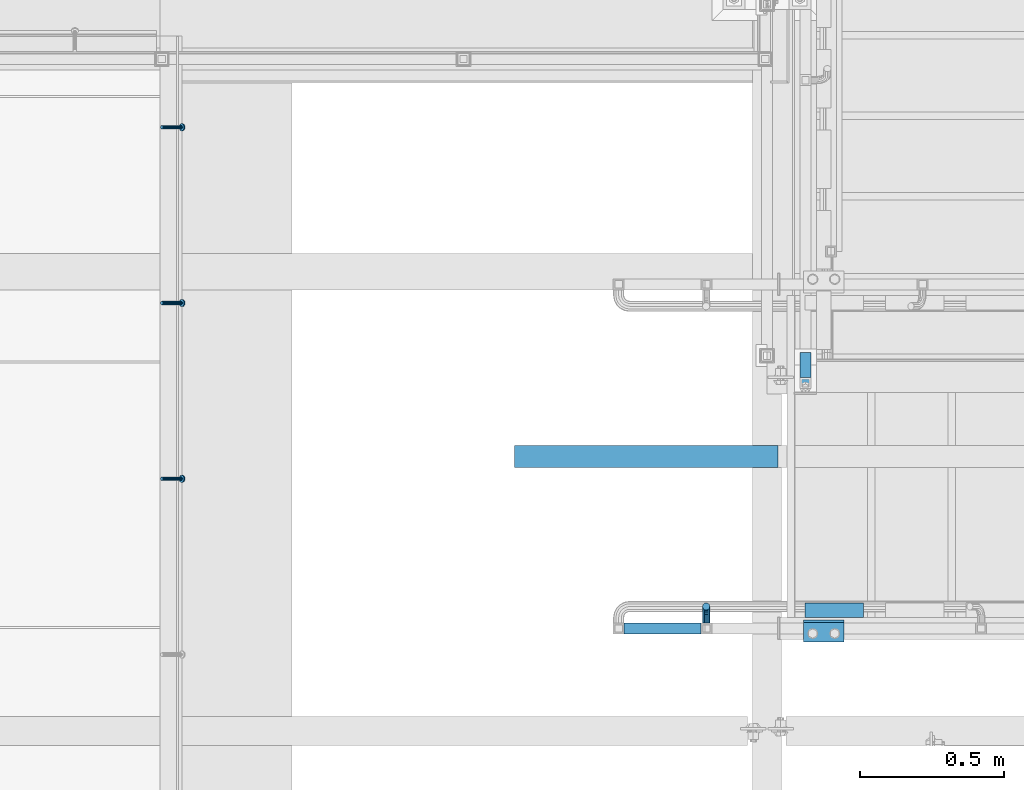
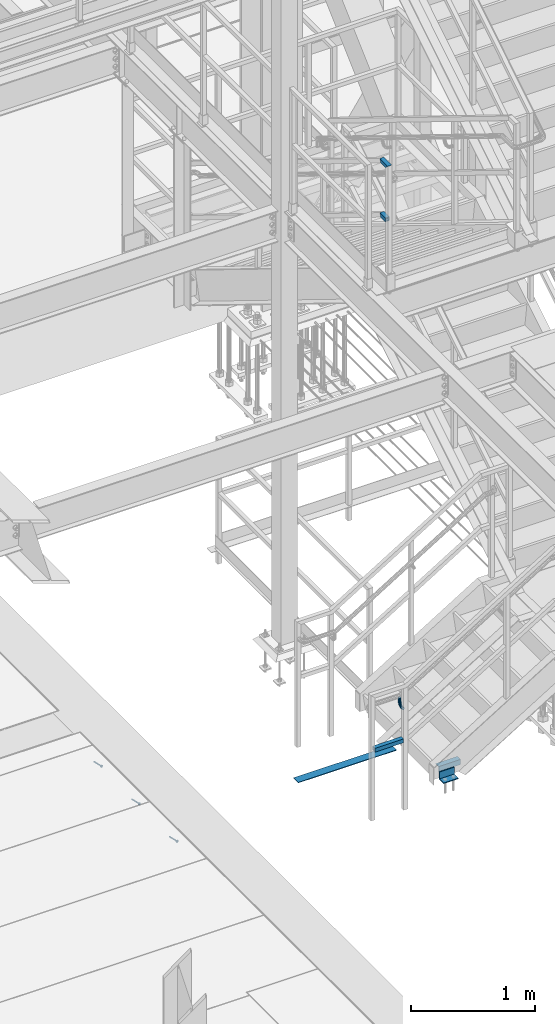
# One storey, part 2060 of 3843: 6 beams, 4 members, 5 elements without a shape of their own.
"""IFC2X3 building model written with IfcOpenShell, lengths in millimetres."""

import ifcopenshell
import ifcopenshell.guid

model = None  # the IFC model being written
_history = None  # IfcOwnerHistory: only IFC2X3 demands one
_inside = {}  # id of a spatial element -> (the spatial element, [elements in it])
_under = {}  # id of a project, library or spatial element -> (it, [spatial elements below it])
_declared = {}  # id of a project -> (the project, [libraries it declares])
_typed = {}  # id of a type object -> (the type object, [elements of that type])
_made_of = {}  # id of a material, layer set ... -> (it, [elements and type objects made of it])


def new_model(schema):
    """Start an empty IFC model of exactly this schema.

    Asked for "IFC4X3", IfcOpenShell would pick the latest addendum, in which some entities
    have other attributes; the version numbers below select the first issue.
    IFC2X3 requires an IfcOwnerHistory on every rooted entity: one is made here for all.
    """
    global model, _history
    if schema == "IFC4X3":
        model = ifcopenshell.file(schema_version=(4, 3, 0, 0))
    else:
        model = ifcopenshell.file(schema=schema)
    _inside.clear()
    _under.clear()
    _declared.clear()
    _typed.clear()
    _made_of.clear()
    _history = None
    if model.schema == "IFC2X3":
        org = make("IfcOrganization", Name="unknown")
        user = make(
            "IfcPersonAndOrganization",
            ThePerson=make("IfcPerson", FamilyName="unknown"),
            TheOrganization=org,
        )
        app = make(
            "IfcApplication",
            ApplicationDeveloper=org,
            Version="unknown",
            ApplicationFullName="unknown",
            ApplicationIdentifier="unknown",
        )
        _history = make(
            "IfcOwnerHistory",
            OwningUser=user,
            OwningApplication=app,
            ChangeAction="ADDED",
            CreationDate=0,
        )
    return model


def make(cls, **values):
    """One entity of the class cls with the attributes given. An attribute that is None is left unset."""
    return model.create_entity(
        cls, **{name: value for name, value in values.items() if value is not None}
    )


def rooted(cls, **values):
    """An entity with a GlobalId (a new one), such as an element, a storey or a relation."""
    return make(cls, GlobalId=ifcopenshell.guid.new(), OwnerHistory=_history, **values)


def si_unit(unit_type, name, prefix=None):
    """IfcSIUnit, for example si_unit("LENGTHUNIT", "METRE", prefix="MILLI")."""
    return make("IfcSIUnit", UnitType=unit_type, Prefix=prefix, Name=name)


def assignment(units):
    """IfcUnitAssignment: the units of a project."""
    return None if units is None else make("IfcUnitAssignment", Units=units)


def point(xyz):
    """IfcCartesianPoint."""
    return None if xyz is None else make("IfcCartesianPoint", Coordinates=xyz)


def direction(xyz):
    """IfcDirection."""
    return None if xyz is None else make("IfcDirection", DirectionRatios=xyz)


def frame(location, z_axis=None, x_axis=None):
    """IfcAxis2Placement3D, a coordinate frame: its origin and axes. An axis left out is left unset."""
    return make(
        "IfcAxis2Placement3D",
        Location=point(location),
        Axis=direction(z_axis),
        RefDirection=direction(x_axis),
    )


def origin_with_axes():
    """The frame at (0, 0, 0) with the z axis (0, 0, 1) and the x axis (1, 0, 0) written out."""
    return frame((0.0, 0.0, 0.0), z_axis=(0.0, 0.0, 1.0), x_axis=(1.0, 0.0, 0.0))


def place(relative_to, where):
    """IfcLocalPlacement: puts the frame where relative to a parent placement (None: the world)."""
    return make(
        "IfcLocalPlacement", PlacementRelTo=relative_to, RelativePlacement=where
    )


def context(
    kind, dimensions, precision=None, world=None, true_north=None, identifier=None
):
    """IfcGeometricRepresentationContext, for example the 3D "Model" context."""
    return make(
        "IfcGeometricRepresentationContext",
        ContextIdentifier=identifier,
        ContextType=kind,
        CoordinateSpaceDimension=dimensions,
        Precision=precision,
        WorldCoordinateSystem=world,
        TrueNorth=true_north,
    )


def subcontext(parent, identifier, kind, view, scale=None):
    """IfcGeometricRepresentationSubContext, for example "Body" below "Model"."""
    return make(
        "IfcGeometricRepresentationSubContext",
        ContextIdentifier=identifier,
        ContextType=kind,
        ParentContext=parent,
        TargetScale=scale,
        TargetView=view,
    )


def project(units=None, contexts=None):
    """IfcProject with its units and contexts."""
    return rooted(
        "IfcProject",
        Name="project",
        RepresentationContexts=contexts,
        UnitsInContext=assignment(units),
    )


def spatial(cls, under=None, at=None, **own):
    """A site, building, storey or space (cls), placed at a placement, below another one or the project."""
    s = rooted(cls, ObjectPlacement=at, **own)
    if under is not None:
        _under.setdefault(under.id(), (under, []))[1].append(s)
    return s


def faces_of(points, faces, orient=None, outer=None):
    """IfcFace entities. A face is a list of loops; a loop is a list of indices into points, from 0.

    orient and outer hold one flag for each loop. By default every Orientation is true, the
    first loop of a face is its IfcFaceOuterBound and the others are IfcFaceBound.
    """
    made = []
    for i, loops in enumerate(faces):
        bounds = []
        for j, loop in enumerate(loops):
            is_outer = j == 0 if outer is None else outer[i][j]
            bounds.append(
                make(
                    "IfcFaceOuterBound" if is_outer else "IfcFaceBound",
                    Bound=make("IfcPolyLoop", Polygon=[points[k] for k in loop]),
                    Orientation=True if orient is None else orient[i][j],
                )
            )
        made.append(make("IfcFace", Bounds=bounds))
    return made


def faceted_brep(points, faces, orient=None, outer=None, voids=None):
    """IfcFacetedBrep: a solid bounded by flat faces; with voids (closed shells), ...WithVoids."""
    shared = [point(p) for p in points]
    hull = make("IfcClosedShell", CfsFaces=faces_of(shared, faces, orient, outer))
    if voids is None:
        return make("IfcFacetedBrep", Outer=hull)
    return make(
        "IfcFacetedBrepWithVoids",
        Outer=hull,
        Voids=[
            make(cls, CfsFaces=faces_of(shared, fs, o, b)) for cls, fs, o, b in voids
        ],
    )


def shape(context_of_items, identifier, shape_type, items):
    """IfcShapeRepresentation: the items that make up one representation, for example the "Body"."""
    return make(
        "IfcShapeRepresentation",
        ContextOfItems=context_of_items,
        RepresentationIdentifier=identifier,
        RepresentationType=shape_type,
        Items=items,
    )


def material(Name=None, Category=None):
    """IfcMaterial."""
    return make("IfcMaterial", Name=Name, Category=Category)


def made_of(thing, what):
    """Note that an element or type object is made of a material, layer set ...; save() writes the relation."""
    if what is not None:
        _made_of.setdefault(what.id(), (what, []))[1].append(thing)
    return thing


def type_object(cls, material=None, **own):
    """A type object (cls), such as IfcWallType, which elements share."""
    return made_of(rooted(cls, **own), material)


def element(
    cls,
    number,
    at=None,
    inside=None,
    cuts=None,
    type_object=None,
    material=None,
    context=None,
    identifier="Body",
    shape_type=None,
    held_by="IfcProductDefinitionShape",
    body=None,
    shapes=None,
    **own,
):
    """One element of the class cls, such as IfcWall. Its Tag is "e" and its number.

    at: its placement. inside: the storey or other place that contains it. cuts: it is an
    opening in that element (IfcRelVoidsElement). A single representation is given by context,
    identifier, shape_type and body (its items); several are given by shapes. held_by: the class
    of the entity that holds the representations. save() writes the other relations.
    """
    e = rooted(cls, Tag="e%d" % number, ObjectPlacement=at, **own)
    if body is not None:
        shapes = [shape(context, identifier, shape_type, body)]
    if shapes is not None:
        e.Representation = make(held_by, Representations=shapes)
    if inside is not None:
        _inside.setdefault(inside.id(), (inside, []))[1].append(e)
    if cuts is not None:
        rooted(
            "IfcRelVoidsElement", RelatingBuildingElement=cuts, RelatedOpeningElement=e
        )
    if type_object is not None:
        _typed.setdefault(type_object.id(), (type_object, []))[1].append(e)
    return made_of(e, material)


def aggregate(whole, parts):
    """IfcRelAggregates: a whole, such as a stair, and the parts it consists of."""
    return rooted("IfcRelAggregates", RelatingObject=whole, RelatedObjects=parts)


def save(model, path):
    """Write the relations noted so far, then the file.

    IfcRelAggregates (storeys below a building ...), IfcRelContainedInSpatialStructure (elements
    in a storey), IfcRelDefinesByType, IfcRelAssociatesMaterial and IfcRelDeclares: one each for
    every whole, place, type object, material and project.
    """
    for whole, parts in _under.values():
        aggregate(whole, parts)
    for where, things in _inside.values():
        rooted(
            "IfcRelContainedInSpatialStructure",
            RelatedElements=things,
            RelatingStructure=where,
        )
    for kind, things in _typed.values():
        rooted("IfcRelDefinesByType", RelatedObjects=things, RelatingType=kind)
    for what, things in _made_of.values():
        rooted("IfcRelAssociatesMaterial", RelatedObjects=things, RelatingMaterial=what)
    for by, libraries in _declared.values():
        rooted("IfcRelDeclares", RelatingContext=by, RelatedDefinitions=libraries)
    model.write(path)


model = new_model("IFC2X3")

# Units and contexts
model_context = context("Model", 3, precision=1e-05, world=origin_with_axes())
body_context = subcontext(model_context, "Body", "Model", "MODEL_VIEW")
ifc_project = project(units=[si_unit("LENGTHUNIT", "METRE", prefix="MILLI"), si_unit("AREAUNIT", "SQUARE_METRE"), si_unit("VOLUMEUNIT", "CUBIC_METRE"), si_unit("MASSUNIT", "GRAM", prefix="KILO"), si_unit("TIMEUNIT", "SECOND"), si_unit("PLANEANGLEUNIT", "RADIAN"), si_unit("SOLIDANGLEUNIT", "STERADIAN"), si_unit("THERMODYNAMICTEMPERATUREUNIT", "DEGREE_CELSIUS"), si_unit("LUMINOUSINTENSITYUNIT", "LUMEN")], contexts=[model_context])

# Site, building, storey
site_placement = place(None, origin_with_axes())
site = spatial("IfcSite", under=ifc_project, at=site_placement, CompositionType="ELEMENT")
building_placement = place(site_placement, origin_with_axes())
building = spatial("IfcBuilding", under=site, at=building_placement, Name="Undefined", CompositionType="ELEMENT")
storey_placement = place(building_placement, origin_with_axes())
storey = spatial("IfcBuildingStorey", under=building, at=storey_placement, Name="Undefined", CompositionType="ELEMENT", Elevation=0.0)

# Assembly, members
assembly_1_placement = place(storey_placement, origin_with_axes())
assembly_1 = element("IfcElementAssembly", 1, at=assembly_1_placement, inside=storey, Name="ANGLE", AssemblyPlace="NOTDEFINED", PredefinedType="RIGID_FRAME")
ifc_material_1 = material(Name="STEEL/A108")
member_type_1 = type_object("IfcMemberType", PredefinedType="NOTDEFINED")
member_1_placement = place(assembly_1_placement, frame((50892.075, 18527.7125, 30397.4500030517), z_axis=(0.0, 1.0, 0.0), x_axis=(0.707106781186548, 0.0, -0.707106781186548)))
member_1 = element("IfcMember", 2, at=member_1_placement, type_object=member_type_1, material=ifc_material_1, Name="HEADED STUD ANCHOR", context=body_context, shape_type="Brep", body=[
    faceted_brep([(7.27595761418343e-12, -3.18000006675175, 5.5), (0.0, -5.49999999998363, 3.1800000667572), (94.4879985803855, -5.50000000011278, 3.1800000667572), (94.4879985803782, -3.18000006687362, 5.5), (0.0, -6.3499999046162, 0.0), (94.4879985803855, -6.34999990474535, 0.0), (0.0, -5.49999999998363, -3.1800000667572), (94.4879985803855, -5.50000000011278, -3.1800000667572), (7.27595761418343e-12, -3.18000006675175, -5.5), (94.4879985803782, -3.18000006687362, -5.5), (7.27595761418343e-12, -1.81898940354586e-12, -6.34999990463257), (94.4879985803782, -1.20053300634027e-10, -6.34999990463257), (0.0, 3.18000006675175, -5.5), (94.4879985803709, 3.18000006663351, -5.5), (7.27595761418343e-12, 5.49999999998363, -3.1800000667572), (94.4879985803709, 5.49999999987267, -3.1800000667572), (7.27595761418343e-12, 6.3499999046162, 0.0), (94.4879985803673, 6.34999990450706, 0.0), (7.27595761418343e-12, 5.49999999998363, 3.1800000667572), (94.4879985803709, 5.49999999987267, 3.1800000667572), (0.0, 3.18000006675175, 5.5), (94.4879985803709, 3.18000006663351, 5.5), (7.27595761418343e-12, -1.81898940354586e-12, 6.34999990463257), (94.4879985803782, -1.20053300634027e-10, 6.34999990463257), (96.5199985498621, -10.9899997712273, 6.34999990463257), (96.5199985498548, -6.34000015270249, 10.9899997711182), (96.5199985498621, -12.6999998093743, 0.0), (96.5199985498621, -10.9899997712273, -6.34999990463257), (96.5199985498548, -6.34000015270249, -10.9899997711182), (96.5199985498475, -1.21872290037572e-10, -12.6899995803833), (96.5199985498402, 6.34000015245874, -10.9899997711182), (96.519998549833, 10.9899997709817, -6.34999990463257), (96.519998549833, 12.6999998091305, 0.0), (96.519998549833, 10.9899997709817, 6.34999990463257), (96.5199985498402, 6.34000015245874, 10.9899997711182), (96.5199985498475, -1.21872290037572e-10, 12.6899995803833), (101.599998473539, -10.9899997712328, 6.34999990463257), (101.599998473532, -6.34000015270976, 10.9899997711182), (101.599998473539, -12.6999998093797, 0.0), (101.599998473539, -10.9899997712328, -6.34999990463257), (101.599998473532, -6.34000015270976, -10.9899997711182), (101.599998473524, -1.29148247651756e-10, -12.6899995803833), (101.599998473517, 6.34000015245329, -10.9899997711182), (101.59999847351, 10.9899997709763, -6.34999990463257), (101.599998473503, 12.6999998091196, 0.0), (101.59999847351, 10.9899997709763, 6.34999990463257), (101.599998473517, 6.34000015245329, 10.9899997711182), (101.599998473524, -1.29148247651756e-10, 12.6899995803833)], [[[0, 1, 2, 3]], [[1, 4, 5, 2]], [[4, 6, 7, 5]], [[6, 8, 9, 7]], [[8, 10, 11, 9]], [[10, 12, 13, 11]], [[12, 14, 15, 13]], [[14, 16, 17, 15]], [[16, 18, 19, 17]], [[18, 20, 21, 19]], [[20, 22, 23, 21]], [[22, 0, 3, 23]], [[22, 20, 18, 16, 14, 12, 10, 8, 6, 4, 1, 0]], [[3, 2, 24, 25]], [[2, 5, 26, 24]], [[5, 7, 27, 26]], [[7, 9, 28, 27]], [[9, 11, 29, 28]], [[11, 13, 30, 29]], [[13, 15, 31, 30]], [[15, 17, 32, 31]], [[17, 19, 33, 32]], [[19, 21, 34, 33]], [[21, 23, 35, 34]], [[23, 3, 25, 35]], [[25, 24, 36, 37]], [[24, 26, 38, 36]], [[26, 27, 39, 38]], [[27, 28, 40, 39]], [[28, 29, 41, 40]], [[29, 30, 42, 41]], [[30, 31, 43, 42]], [[31, 32, 44, 43]], [[32, 33, 45, 44]], [[33, 34, 46, 45]], [[34, 35, 47, 46]], [[35, 25, 37, 47]], [[38, 39, 40, 41, 42, 43, 44, 45, 46, 47, 37, 36]]]),
])
member_2_placement = place(assembly_1_placement, frame((50892.075, 19137.3125, 30397.4500030517), z_axis=(0.0, 1.0, 0.0), x_axis=(0.707106781186548, 0.0, -0.707106781186548)))
member_2 = element("IfcMember", 3, at=member_2_placement, type_object=member_type_1, material=ifc_material_1, Name="HEADED STUD ANCHOR", context=body_context, shape_type="Brep", body=[
    faceted_brep([(7.27595761418343e-12, -3.18000006675175, 5.5), (0.0, -5.49999999998363, 3.1800000667572), (94.4879985803855, -5.50000000011278, 3.1800000667572), (94.4879985803782, -3.18000006687362, 5.5), (0.0, -6.3499999046162, 0.0), (94.4879985803855, -6.34999990474535, 0.0), (0.0, -5.49999999998363, -3.1800000667572), (94.4879985803855, -5.50000000011278, -3.1800000667572), (7.27595761418343e-12, -3.18000006675175, -5.5), (94.4879985803782, -3.18000006687362, -5.5), (7.27595761418343e-12, -1.81898940354586e-12, -6.34999990463257), (94.4879985803782, -1.20053300634027e-10, -6.34999990463257), (0.0, 3.18000006675175, -5.5), (94.4879985803709, 3.18000006663351, -5.5), (7.27595761418343e-12, 5.49999999998363, -3.1800000667572), (94.4879985803709, 5.49999999987267, -3.1800000667572), (7.27595761418343e-12, 6.3499999046162, 0.0), (94.4879985803673, 6.34999990450706, 0.0), (7.27595761418343e-12, 5.49999999998363, 3.1800000667572), (94.4879985803709, 5.49999999987267, 3.1800000667572), (0.0, 3.18000006675175, 5.5), (94.4879985803709, 3.18000006663351, 5.5), (7.27595761418343e-12, -1.81898940354586e-12, 6.34999990463257), (94.4879985803782, -1.20053300634027e-10, 6.34999990463257), (96.5199985498621, -10.9899997712273, 6.34999990463257), (96.5199985498548, -6.34000015270249, 10.9899997711182), (96.5199985498621, -12.6999998093743, 0.0), (96.5199985498621, -10.9899997712273, -6.34999990463257), (96.5199985498548, -6.34000015270249, -10.9899997711182), (96.5199985498475, -1.21872290037572e-10, -12.6899995803833), (96.5199985498402, 6.34000015245874, -10.9899997711182), (96.519998549833, 10.9899997709817, -6.34999990463257), (96.519998549833, 12.6999998091305, 0.0), (96.519998549833, 10.9899997709817, 6.34999990463257), (96.5199985498402, 6.34000015245874, 10.9899997711182), (96.5199985498475, -1.21872290037572e-10, 12.6899995803833), (101.599998473539, -10.9899997712328, 6.34999990463257), (101.599998473532, -6.34000015270976, 10.9899997711182), (101.599998473539, -12.6999998093797, 0.0), (101.599998473539, -10.9899997712328, -6.34999990463257), (101.599998473532, -6.34000015270976, -10.9899997711182), (101.599998473524, -1.29148247651756e-10, -12.6899995803833), (101.599998473517, 6.34000015245329, -10.9899997711182), (101.59999847351, 10.9899997709763, -6.34999990463257), (101.599998473503, 12.6999998091196, 0.0), (101.59999847351, 10.9899997709763, 6.34999990463257), (101.599998473517, 6.34000015245329, 10.9899997711182), (101.599998473524, -1.29148247651756e-10, 12.6899995803833)], [[[0, 1, 2, 3]], [[1, 4, 5, 2]], [[4, 6, 7, 5]], [[6, 8, 9, 7]], [[8, 10, 11, 9]], [[10, 12, 13, 11]], [[12, 14, 15, 13]], [[14, 16, 17, 15]], [[16, 18, 19, 17]], [[18, 20, 21, 19]], [[20, 22, 23, 21]], [[22, 0, 3, 23]], [[22, 20, 18, 16, 14, 12, 10, 8, 6, 4, 1, 0]], [[3, 2, 24, 25]], [[2, 5, 26, 24]], [[5, 7, 27, 26]], [[7, 9, 28, 27]], [[9, 11, 29, 28]], [[11, 13, 30, 29]], [[13, 15, 31, 30]], [[15, 17, 32, 31]], [[17, 19, 33, 32]], [[19, 21, 34, 33]], [[21, 23, 35, 34]], [[23, 3, 25, 35]], [[25, 24, 36, 37]], [[24, 26, 38, 36]], [[26, 27, 39, 38]], [[27, 28, 40, 39]], [[28, 29, 41, 40]], [[29, 30, 42, 41]], [[30, 31, 43, 42]], [[31, 32, 44, 43]], [[32, 33, 45, 44]], [[33, 34, 46, 45]], [[34, 35, 47, 46]], [[35, 25, 37, 47]], [[38, 39, 40, 41, 42, 43, 44, 45, 46, 47, 37, 36]]]),
])
member_3_placement = place(assembly_1_placement, frame((50892.075, 19746.9125, 30397.4500030517), z_axis=(0.0, 1.0, 0.0), x_axis=(0.707106781186548, 0.0, -0.707106781186548)))
member_3 = element("IfcMember", 4, at=member_3_placement, type_object=member_type_1, material=ifc_material_1, Name="HEADED STUD ANCHOR", context=body_context, shape_type="Brep", body=[
    faceted_brep([(7.27595761418343e-12, -3.18000006675175, 5.5), (0.0, -5.49999999998363, 3.1800000667572), (94.4879985803855, -5.50000000011278, 3.1800000667572), (94.4879985803782, -3.18000006687362, 5.5), (0.0, -6.3499999046162, 0.0), (94.4879985803855, -6.34999990474535, 0.0), (0.0, -5.49999999998363, -3.1800000667572), (94.4879985803855, -5.50000000011278, -3.1800000667572), (7.27595761418343e-12, -3.18000006675175, -5.5), (94.4879985803782, -3.18000006687362, -5.5), (7.27595761418343e-12, -1.81898940354586e-12, -6.34999990463257), (94.4879985803782, -1.20053300634027e-10, -6.34999990463257), (0.0, 3.18000006675175, -5.5), (94.4879985803709, 3.18000006663351, -5.5), (7.27595761418343e-12, 5.49999999998363, -3.1800000667572), (94.4879985803709, 5.49999999987267, -3.1800000667572), (7.27595761418343e-12, 6.3499999046162, 0.0), (94.4879985803673, 6.34999990450706, 0.0), (7.27595761418343e-12, 5.49999999998363, 3.1800000667572), (94.4879985803709, 5.49999999987267, 3.1800000667572), (0.0, 3.18000006675175, 5.5), (94.4879985803709, 3.18000006663351, 5.5), (7.27595761418343e-12, -1.81898940354586e-12, 6.34999990463257), (94.4879985803782, -1.20053300634027e-10, 6.34999990463257), (96.5199985498621, -10.9899997712273, 6.34999990463257), (96.5199985498548, -6.34000015270249, 10.9899997711182), (96.5199985498621, -12.6999998093743, 0.0), (96.5199985498621, -10.9899997712273, -6.34999990463257), (96.5199985498548, -6.34000015270249, -10.9899997711182), (96.5199985498475, -1.21872290037572e-10, -12.6899995803833), (96.5199985498402, 6.34000015245874, -10.9899997711182), (96.519998549833, 10.9899997709817, -6.34999990463257), (96.519998549833, 12.6999998091305, 0.0), (96.519998549833, 10.9899997709817, 6.34999990463257), (96.5199985498402, 6.34000015245874, 10.9899997711182), (96.5199985498475, -1.21872290037572e-10, 12.6899995803833), (101.599998473539, -10.9899997712328, 6.34999990463257), (101.599998473532, -6.34000015270976, 10.9899997711182), (101.599998473539, -12.6999998093797, 0.0), (101.599998473539, -10.9899997712328, -6.34999990463257), (101.599998473532, -6.34000015270976, -10.9899997711182), (101.599998473524, -1.29148247651756e-10, -12.6899995803833), (101.599998473517, 6.34000015245329, -10.9899997711182), (101.59999847351, 10.9899997709763, -6.34999990463257), (101.599998473503, 12.6999998091196, 0.0), (101.59999847351, 10.9899997709763, 6.34999990463257), (101.599998473517, 6.34000015245329, 10.9899997711182), (101.599998473524, -1.29148247651756e-10, 12.6899995803833)], [[[0, 1, 2, 3]], [[1, 4, 5, 2]], [[4, 6, 7, 5]], [[6, 8, 9, 7]], [[8, 10, 11, 9]], [[10, 12, 13, 11]], [[12, 14, 15, 13]], [[14, 16, 17, 15]], [[16, 18, 19, 17]], [[18, 20, 21, 19]], [[20, 22, 23, 21]], [[22, 0, 3, 23]], [[22, 20, 18, 16, 14, 12, 10, 8, 6, 4, 1, 0]], [[3, 2, 24, 25]], [[2, 5, 26, 24]], [[5, 7, 27, 26]], [[7, 9, 28, 27]], [[9, 11, 29, 28]], [[11, 13, 30, 29]], [[13, 15, 31, 30]], [[15, 17, 32, 31]], [[17, 19, 33, 32]], [[19, 21, 34, 33]], [[21, 23, 35, 34]], [[23, 3, 25, 35]], [[25, 24, 36, 37]], [[24, 26, 38, 36]], [[26, 27, 39, 38]], [[27, 28, 40, 39]], [[28, 29, 41, 40]], [[29, 30, 42, 41]], [[30, 31, 43, 42]], [[31, 32, 44, 43]], [[32, 33, 45, 44]], [[33, 34, 46, 45]], [[34, 35, 47, 46]], [[35, 25, 37, 47]], [[38, 39, 40, 41, 42, 43, 44, 45, 46, 47, 37, 36]]]),
])
aggregate(assembly_1, [member_1, member_2, member_3])

# Assembly, beam
assembly_2_placement = place(storey_placement, origin_with_axes())
assembly_2 = element("IfcElementAssembly", 5, at=assembly_2_placement, inside=storey, Name="STAIR", AssemblyPlace="NOTDEFINED", PredefinedType="RIGID_FRAME")
ifc_material_2 = material(Name="STEEL/A36")
beam_type_1 = type_object("IfcBeamType", Name="L3X3X3/8", PredefinedType="NOTDEFINED")
beam_1_placement = place(assembly_2_placement, frame((53257.45, 18000.6625000644, 30518.1), z_axis=(0.0, -1.0, 0.0), x_axis=(-1.0, 0.0, 0.0)))
beam_1 = element("IfcBeam", 6, at=beam_1_placement, type_object=beam_type_1, material=ifc_material_2, Name="CLEAT", ObjectType="L3X3X3/8", context=body_context, shape_type="Brep", body=[
    faceted_brep([(0.0, 38.0999999999985, -38.0999999999985), (0.0, 38.0999999999985, 38.0999999999985), (139.699999999997, 38.0999999999985, 38.0999999999985), (139.699999999997, 38.0999999999985, -38.0999999999985), (0.0, 28.5750000000007, 38.0999999999985), (139.699999999997, 28.5750000000007, 38.0999999999985), (0.0, 28.5750000000007, -28.5750000000007), (139.699999999997, 28.5750000000007, -28.5750000000007), (0.0, -38.0999999999985, -28.5750000000007), (139.699999999997, -38.0999999999985, -28.5750000000007), (0.0, -38.0999999999985, -38.0999999999985), (139.699999999997, -38.0999999999985, -38.0999999999985)], [[[0, 1, 2, 3]], [[1, 4, 5, 2]], [[4, 6, 7, 5]], [[6, 8, 9, 7]], [[8, 10, 11, 9]], [[10, 0, 3, 11]], [[5, 7, 9, 11, 3, 2]], [[10, 8, 6, 4, 1, 0]]]),
])

# Assembly, beams
assembly_3_placement = place(storey_placement, origin_with_axes())
assembly_3 = element("IfcElementAssembly", 7, at=assembly_3_placement, inside=storey, Name="RAIL", AssemblyPlace="NOTDEFINED", PredefinedType="RIGID_FRAME")
ifc_material_3 = material()
beam_type_2 = type_object("IfcBeamType", Name="HSS1-1/2X1-1/2X1/4", PredefinedType="NOTDEFINED")
beam_2_placement = place(assembly_3_placement, frame((53124.1, 18961.0999971375, 35483.7999969347), z_axis=(0.0, 0.0, 1.0), x_axis=(0.0, -1.0, 0.0)))
beam_2 = element("IfcBeam", 8, at=beam_2_placement, type_object=beam_type_2, material=ifc_material_3, Name="RAIL", ObjectType="HSS1-1/2X1-1/2X1/4", context=body_context, shape_type="Brep", body=[
    faceted_brep([(3.59463564452017, 12.6999993300014, -12.6999993299978), (3.59463564452017, -12.6999993300014, -12.6999993299978), (82.5500000532629, -12.6999993300014, -12.6999993299978), (82.5500000532629, 12.6999993300014, -12.6999993299978), (-3.59463560431323, -12.6999993300014, 12.6999993299978), (82.5500000532629, -12.6999993300014, 12.6999993299978), (-3.59463560431323, 12.6999993300014, 12.6999993299978), (82.5500000532629, 12.6999993300014, 12.6999993299978), (5.39195352466777, 19.0499992350015, -19.0499992350015), (-5.39195348444628, 19.0499992350015, 19.0499992350015), (82.5500000532629, 19.0499992350015, 19.0499992350015), (82.5500000532629, 19.0499992350015, -19.0499992350015), (-5.39195348444628, -19.0499992350015, 19.0499992350015), (82.5500000532629, -19.0499999999993, 19.0499992350015), (5.39195352466777, -19.0499992350015, -19.0499992350015), (82.5500000532629, -19.0499992350015, -19.0499992350015)], [[[0, 1, 2, 3]], [[1, 4, 5, 2]], [[4, 6, 7, 5]], [[6, 0, 3, 7]], [[8, 9, 10, 11]], [[9, 12, 13, 10]], [[12, 14, 15, 13]], [[14, 8, 11, 15]], [[13, 15, 11, 10], [5, 7, 3, 2]], [[14, 12, 9, 8], [6, 4, 1, 0]]]),
])
beam_3_placement = place(assembly_3_placement, frame((53124.1, 18859.4999999849, 36017.199996934), z_axis=(0.0, 0.0, -1.0), x_axis=(0.0, 1.0, 0.0)))
beam_3 = element("IfcBeam", 9, at=beam_3_placement, type_object=beam_type_2, material=ifc_material_3, Name="RAIL", ObjectType="HSS1-1/2X1-1/2X1/4", context=body_context, shape_type="Brep", body=[
    faceted_brep([(-12.6999993309546, 12.6999993299978, -12.6999993299978), (-12.6999993309546, -12.6999993299978, -12.6999993299978), (105.194632755753, -12.6999993299978, -12.6999993299978), (105.194632755753, 12.6999993299978, -12.6999993299978), (12.6999993290483, -12.6999993299978, 12.6999993299978), (98.0053615143879, -12.6999993299978, 12.6999993299978), (12.6999993290483, 12.6999993299978, 12.6999993299978), (98.0053615143879, 12.6999993299978, 12.6999993299978), (-19.0499992359546, 19.0499992350015, -19.0499992350015), (19.0499992350015, 19.0499992350015, 19.0499992350015), (96.2080436361175, 19.0499992350015, 19.0499992350015), (106.991950634023, 19.0499992350015, -19.0499992350015), (19.0499992350015, -19.0499992350015, 19.0499992350015), (96.2080436361175, -19.0499992350015, 19.0499992350015), (-19.0499992359546, -19.0499992350015, -19.0499992350015), (106.991950634023, -19.0499992350015, -19.0499992350015)], [[[0, 1, 2, 3]], [[1, 4, 5, 2]], [[4, 6, 7, 5]], [[6, 0, 3, 7]], [[8, 9, 10, 11]], [[9, 12, 13, 10]], [[12, 14, 15, 13]], [[14, 8, 11, 15]], [[13, 15, 11, 10], [5, 7, 3, 2]], [[14, 12, 9, 8], [6, 4, 1, 0]]]),
])
aggregate(assembly_3, [beam_2, beam_3])

# Assembly, beam
assembly_4_placement = place(storey_placement, origin_with_axes())
assembly_4 = element("IfcElementAssembly", 10, at=assembly_4_placement, inside=storey, Name="RAIL", AssemblyPlace="NOTDEFINED", PredefinedType="RIGID_FRAME")
beam_4_placement = place(assembly_4_placement, frame((52476.3999999909, 18008.6000001452, 31013.4), z_axis=(0.0, 0.0, 1.0), x_axis=(1.0, 0.0, 0.0)))
beam_4 = element("IfcBeam", 11, at=beam_4_placement, type_object=beam_type_2, material=ifc_material_3, Name="RAIL", ObjectType="HSS1-1/2X1-1/2X1/4", context=body_context, shape_type="Brep", body=[
    faceted_brep([(19.0499992350015, -19.0499992350015, 19.0499992350015), (19.0499992350015, -19.0499992350015, -19.0499992350015), (285.750000765285, -19.0499992350015, -19.0499992350015), (285.750000765285, -19.0499992350015, 19.0499992350015), (19.0499992350015, 19.0499992350015, 19.0499992350015), (19.0500015258804, 0.0, 19.0500000000029), (285.75000076498, 0.0, 19.0499992350015), (285.750000765285, 19.0499992350015, 19.0499992350015), (19.0499992350015, 19.0499992350015, -19.0499992350015), (285.750000765285, 19.0499992350015, -19.0499992350015), (19.0500015258804, 0.0, -19.0500000000029), (19.0499992350015, 12.6999993299978, -12.6999993299978), (19.0499992350015, 12.6999993299978, 12.6999993299978), (19.0500015258731, 0.0, 12.6999999999971), (19.0499992350015, -12.6999993299978, 12.6999993299978), (19.0499992350015, -12.6999993299978, -12.6999993299978), (19.0500015258731, 0.0, -12.6999999999971), (285.750000765009, 12.6999993300014, -12.6999993299978), (285.750000765009, 12.6999993300014, 12.6999993299978), (285.75000076498, 0.0, 12.6999993300014), (285.750000765009, -12.6999993300014, 12.6999993299978), (285.750000765009, -12.6999993300014, -12.6999993299978), (285.75000076498, 0.0, -12.6999993300014), (285.75000076498, 0.0, -19.0499992350015)], [[[0, 1, 2, 3]], [[4, 5, 0, 3, 6, 7]], [[8, 4, 7, 9]], [[10, 1, 0, 5, 4, 8], [11, 12, 13, 14, 15, 16]], [[12, 11, 17, 18]], [[14, 13, 12, 18, 19, 20]], [[15, 14, 20, 21]], [[11, 16, 15, 21, 22, 17]], [[6, 3, 2, 23, 9, 7], [21, 20, 19, 18, 17, 22]], [[1, 10, 8, 9, 23, 2]]]),
])

# Beam
beam_type_3 = type_object("IfcBeamType", Name="L2X2X3/16", PredefinedType="NOTDEFINED")
beam_5_placement = place(assembly_2_placement, frame((53325.3140030326, 18072.1000001452, 30572.5634614191), z_axis=(0.0, 1.0, 0.0), x_axis=(-1.0, 0.0, 0.0)))
beam_5 = element("IfcBeam", 12, at=beam_5_placement, type_object=beam_type_3, material=ifc_material_2, Name="ANGLE", ObjectType="L2X2X3/16", context=body_context, shape_type="Brep", body=[
    faceted_brep([(0.0, 25.4000000000015, -25.4000000000015), (0.0, 25.4000000000015, 25.4000000000015), (203.199999999997, 25.4000000000015, 25.4000000000015), (203.199999999997, 25.4000000000015, -25.4000000000015), (0.0, 20.6375000000007, 25.4000000000015), (203.199999999997, 20.6375000000007, 25.4000000000015), (0.0, 20.6375000000007, -20.6375000000007), (203.199999999997, 20.6375000000007, -20.6375000000007), (0.0, -25.4000000000015, -20.6375000000007), (203.199999999997, -25.4000000000015, -20.6375000000007), (0.0, -25.4000000000015, -25.4000000000015), (203.199999999997, -25.4000000000015, -25.4000000000015)], [[[0, 1, 2, 3]], [[1, 4, 5, 2]], [[4, 6, 7, 5]], [[6, 8, 9, 7]], [[8, 10, 11, 9]], [[10, 0, 3, 11]], [[5, 7, 9, 11, 3, 2]], [[10, 8, 6, 4, 1, 0]]]),
])

aggregate(assembly_2, [beam_1, beam_5])

beam_type_4 = type_object("IfcBeamType", PredefinedType="NOTDEFINED")
beam_6_placement = place(assembly_4_placement, frame((52779.6125002313, 18027.6500001452, 31299.1500000027), z_axis=(1.0, 0.0, 0.0), x_axis=(0.0, 1.0, 0.0)))
beam_6 = element("IfcBeam", 13, at=beam_6_placement, type_object=beam_type_4, material=ifc_material_2, Name="BRACKET ARM", context=body_context, shape_type="Brep", body=[
    faceted_brep([(0.0, -12.6999999999971, 0.0), (0.0, -10.9985226280696, -6.34999999999854), (19.0500015258731, -10.9985226280623, -6.34999999999854), (19.0500015258731, -12.6999999999971, -6.33008312433958e-10), (0.0, -6.35000000000582, -10.9985226280623), (19.0500015258731, -6.34999999999854, -10.9985226280623), (0.0, 0.0, -12.6999999999971), (19.0500015258731, 0.0, -12.6999999999971), (0.0, 6.35000000000582, -10.9985226280623), (19.0500015258731, 6.34999999999854, -10.9985226280623), (0.0, 10.9985226280696, -6.34999999999854), (19.0500015258731, 10.9985226280623, -6.34999999999854), (0.0, 12.6999999999971, 0.0), (19.0500015258731, 12.6999999999971, 0.0), (0.0, 10.9985226280696, 6.34999999999854), (19.0500015258731, 10.9985226280623, 6.34999999999854), (0.0, 6.35000000000582, 10.9985226280623), (19.0500015258731, 6.34999999999854, 10.9985226280623), (0.0, 0.0, 12.6999999999971), (19.0500015258731, 0.0, 12.6999999999971), (0.0, -6.35000000000582, 10.9985226280623), (19.0500015258731, -6.34999999999854, 10.9985226280623), (0.0, -10.9985226280696, 6.34999999999854), (19.0500015258731, -10.9985226280623, 6.34999999999854), (38.4903193060891, -8.8330803677236, -3.34694050252438e-10), (37.8391921052389, -7.26112024908798, 6.34999999974389), (36.0602795104642, -2.96644533684594, 10.9985226280041), (33.6302397149266, 2.90018969451194, 12.7000000002226), (31.2001999194181, 8.76682472604443, 10.9985226285644), (29.4212873247307, 13.061499638774, 6.35000000070431), (28.7701601240115, 14.6334597580644, 7.78527464717627e-10), (29.4212873248762, 13.0614996394288, -6.34999999929278), (31.2001999196509, 8.76682472718676, -10.9985226275603), (33.6302397151885, 2.90018969582889, -12.6999999997788), (36.0602795106824, -2.96644533571089, -10.9985226281206), (37.8391921053699, -7.26112024843314, -6.35000000026048), (53.7678987435793, 3.38210125690239, -6.3499999994383), (54.9710249311902, 2.17897506880399, 5.0931703299284e-10), (50.4808968708676, 6.66910312997061, -10.9985226273784), (45.9907688103704, 11.1592311906061, -12.6999999991458), (41.5006407498004, 15.6493592510378, -10.9985226270364), (38.213638876914, 18.9363611235749, -6.34999999884167), (37.0105126890558, 20.1394873109457, 1.20053300634027e-09), (38.2136388766667, 18.9363611228473, 6.35000000115542), (41.5006407493784, 15.6493592497718, 10.9985226290883), (45.9907688098756, 11.1592311891436, 12.7000000008557), (50.4808968704456, 6.66910312870459, 10.9985226287463), (53.7678987433319, 3.38210125617479, 6.35000000055879), (64.4111202489148, 19.3108078951118, -6.34999999821594), (65.9830803677178, 18.6596806939051, 1.77533365786076e-09), (60.1164453365491, 21.0897204901557, -10.9985226262725), (54.2498103051475, 23.5197602857806, -12.6999999981927), (48.3831752736587, 25.9498000811873, -10.9985226262434), (44.0885003610601, 27.7287126756128, -6.34999999817228), (42.516540241937, 28.3798398759754, 1.83354131877422e-09), (44.08850036074, 27.7287126747688, 6.35000000183209), (48.3831752731057, 25.9498000797321, 10.9985226298813), (54.2498103045073, 23.5197602840999, 12.7000000018088), (60.1164453359961, 21.0897204886933, 10.9985226298522), (64.4111202485947, 19.3108078942678, 6.35000000178115), (68.1485226282239, 38.0999984746086, -6.3499999967753), (69.8499999999913, 38.0999984741211, 2.92493496090174e-09), (63.500000000291, 38.0999984749651, -10.9985226249628), (57.1500000003434, 38.0999984750961, -12.6999999970722), (50.8000000002939, 38.0999984749651, -10.998522625312), (46.1514773720992, 38.0999984746086, -6.34999999737192), (44.4499999999971, 38.0999984741211, 2.58296495303512e-09), (46.1514773717645, 38.0999984736336, 6.35000000262517), (50.7999999996973, 38.0999984732771, 10.9985226308127), (57.1499999996449, 38.0999984731461, 12.700000002922), (63.4999999996944, 38.0999984732771, 10.9985226311619), (68.1485226278892, 38.0999984736336, 6.35000000322179), (68.1485226280638, 76.2000000002372, -6.34999999414867), (69.8499999999913, 76.199999999757, 5.84986992180347e-09), (63.5, 76.200000000601, -10.9985226222125), (57.1499999999942, 76.2000000007247, -12.6999999941472), (50.7999999999884, 76.200000000601, -10.9985226222125), (46.1514773719246, 76.2000000002372, -6.34999999414867), (44.4499999999971, 76.199999999757, 5.84986992180347e-09), (46.1514773719246, 76.1999999992695, 6.35000000584841), (50.7999999999884, 76.1999999989057, 10.9985226339122), (57.1499999999942, 76.199999998782, 12.700000005847), (63.5, 76.1999999989057, 10.9985226339122), (68.1485226280638, 76.1999999992695, 6.35000000584841)], [[[0, 1, 2, 3]], [[1, 4, 5, 2]], [[4, 6, 7, 5]], [[6, 8, 9, 7]], [[8, 10, 11, 9]], [[10, 12, 13, 11]], [[12, 14, 15, 13]], [[14, 16, 17, 15]], [[16, 18, 19, 17]], [[18, 20, 21, 19]], [[20, 22, 23, 21]], [[22, 0, 3, 23]], [[22, 20, 18, 16, 14, 12, 10, 8, 6, 4, 1, 0]], [[23, 3, 24, 25]], [[21, 23, 25, 26]], [[19, 21, 26, 27]], [[17, 19, 27, 28]], [[15, 17, 28, 29]], [[13, 15, 29, 30]], [[11, 13, 30, 31]], [[9, 11, 31, 32]], [[7, 9, 32, 33]], [[5, 7, 33, 34]], [[2, 5, 34, 35]], [[3, 2, 35, 24]], [[35, 36, 37, 24]], [[34, 38, 36, 35]], [[33, 39, 38, 34]], [[32, 40, 39, 33]], [[31, 41, 40, 32]], [[30, 42, 41, 31]], [[29, 43, 42, 30]], [[28, 44, 43, 29]], [[27, 45, 44, 28]], [[26, 46, 45, 27]], [[25, 47, 46, 26]], [[24, 37, 47, 25]], [[36, 48, 49, 37]], [[38, 50, 48, 36]], [[39, 51, 50, 38]], [[40, 52, 51, 39]], [[41, 53, 52, 40]], [[42, 54, 53, 41]], [[43, 55, 54, 42]], [[44, 56, 55, 43]], [[45, 57, 56, 44]], [[46, 58, 57, 45]], [[47, 59, 58, 46]], [[37, 49, 59, 47]], [[48, 60, 61, 49]], [[50, 62, 60, 48]], [[51, 63, 62, 50]], [[52, 64, 63, 51]], [[53, 65, 64, 52]], [[54, 66, 65, 53]], [[55, 67, 66, 54]], [[56, 68, 67, 55]], [[57, 69, 68, 56]], [[58, 70, 69, 57]], [[59, 71, 70, 58]], [[49, 61, 71, 59]], [[61, 60, 72, 73]], [[60, 62, 74, 72]], [[62, 63, 75, 74]], [[63, 64, 76, 75]], [[64, 65, 77, 76]], [[65, 66, 78, 77]], [[66, 67, 79, 78]], [[67, 68, 80, 79]], [[68, 69, 81, 80]], [[69, 70, 82, 81]], [[70, 71, 83, 82]], [[71, 61, 73, 83]], [[74, 75, 76, 77, 78, 79, 80, 81, 82, 83, 73, 72]]]),
])

aggregate(assembly_4, [beam_6, beam_4])

# Assembly, member
assembly_5_placement = place(storey_placement, origin_with_axes())
assembly_5 = element("IfcElementAssembly", 14, at=assembly_5_placement, inside=storey, Name="ref.", AssemblyPlace="NOTDEFINED", PredefinedType="RIGID_FRAME")
ifc_material_4 = material(Name="STEEL/Steel_Undefined")
member_type_2 = type_object("IfcMemberType", PredefinedType="NOTDEFINED")
member_4_placement = place(assembly_5_placement, frame((53028.85, 18605.5000001452, 30476.825), z_axis=(0.0, -1.0, 0.0), x_axis=(-1.0, 0.0, 0.0)))
member_4 = element("IfcMember", 15, at=member_4_placement, type_object=member_type_2, material=ifc_material_4, Name="ref.", context=body_context, shape_type="Brep", body=[
    faceted_brep([(0.0, 3.17500000000291, -38.0999999999985), (0.0, 3.17500000000291, 38.0999999999985), (914.400000000001, 3.17499999999927, 38.0999999999985), (914.400000000001, 3.17499999999927, -38.0999999999985), (0.0, -3.17500000000291, 38.0999999999985), (914.400000000001, -3.17499999999927, 38.0999999999985), (0.0, -3.17500000000291, -38.0999999999985), (914.400000000001, -3.17499999999927, -38.0999999999985)], [[[0, 1, 2, 3]], [[1, 4, 5, 2]], [[4, 6, 7, 5]], [[6, 0, 3, 7]], [[5, 7, 3, 2]], [[6, 4, 1, 0]]]),
])
aggregate(assembly_5, [member_4])

save(model, "model.ifc")
